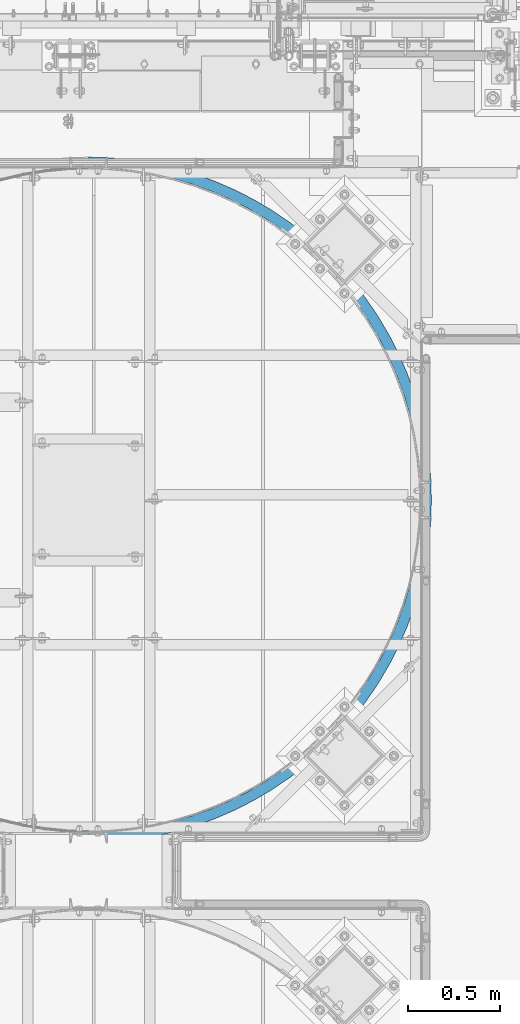
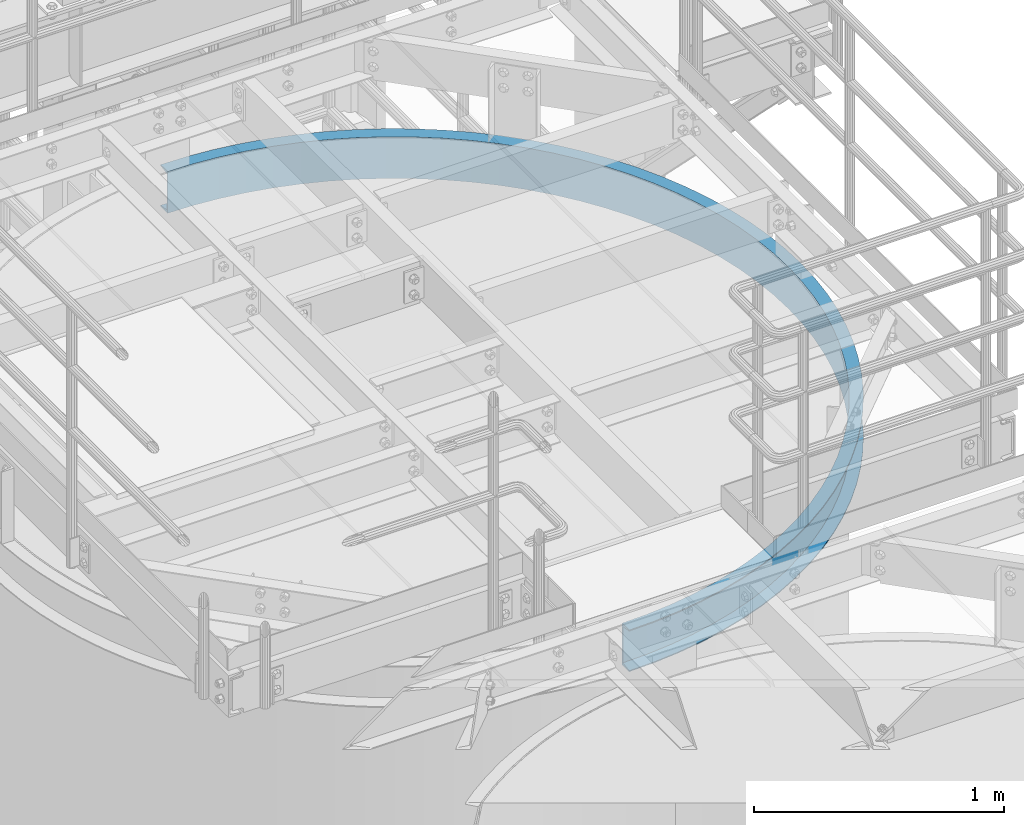
# One storey, part 941 of 1876: 1 beam, 1 element without a shape of its own.
"""IFC2X3 building model written with IfcOpenShell, lengths in millimetres."""

from ifc_helpers import new_model, si_unit, frame, origin_with_axes, place, context, subcontext, project, spatial, faceted_brep, material, type_object, element, aggregate, save


model = new_model("IFC2X3")

# Units and contexts
model_context = context("Model", 3, precision=1e-05, world=origin_with_axes())
body_context = subcontext(model_context, "Body", "Model", "MODEL_VIEW")
ifc_project = project(units=[si_unit("LENGTHUNIT", "METRE", prefix="MILLI"), si_unit("AREAUNIT", "SQUARE_METRE"), si_unit("VOLUMEUNIT", "CUBIC_METRE"), si_unit("MASSUNIT", "GRAM", prefix="KILO"), si_unit("TIMEUNIT", "SECOND"), si_unit("PLANEANGLEUNIT", "RADIAN"), si_unit("SOLIDANGLEUNIT", "STERADIAN"), si_unit("THERMODYNAMICTEMPERATUREUNIT", "DEGREE_CELSIUS"), si_unit("LUMINOUSINTENSITYUNIT", "LUMEN")], contexts=[model_context])

# Site, building, storey
site_placement = place(None, origin_with_axes())
site = spatial("IfcSite", under=ifc_project, at=site_placement, CompositionType="ELEMENT")
building_placement = place(site_placement, origin_with_axes())
building = spatial("IfcBuilding", under=site, at=building_placement, Name="Undefined", CompositionType="ELEMENT")
storey_placement = place(building_placement, origin_with_axes())
storey = spatial("IfcBuildingStorey", under=building, at=storey_placement, Name="Undefined", CompositionType="ELEMENT", Elevation=0.0)

# Assembly, beam
assembly_placement = place(storey_placement, origin_with_axes())
assembly = element("IfcElementAssembly", 1, at=assembly_placement, inside=storey, Name="CHANNEL", AssemblyPlace="NOTDEFINED", PredefinedType="RIGID_FRAME")
ifc_material = material(Name="STEEL/A36")
beam_type = type_object("IfcBeamType", Name="C8X11.5", PredefinedType="NOTDEFINED")
beam_placement = place(assembly_placement, frame((5201.80607653328, -11373.9699317412, 7518.4), z_axis=(0.0, 0.0, 1.0), x_axis=(0.707106781186548, 0.707106781186547, 0.0)))
beam = element("IfcBeam", 2, at=beam_placement, type_object=beam_type, material=ifc_material, Name="CHANNEL", ObjectType="C8X11.5", context=body_context, shape_type="Brep", body=[
    faceted_brep([(-40.4111525448152, -11.8361525448254, -101.6), (-40.4111525448152, -11.8361525448254, -96.8355949999996), (-4.49012806054634, 24.0848719394708, -88.3723149999996), (-4.49012806054634, 24.0848719394708, 88.3723149999996), (-40.4111525448152, -11.8361525448254, 96.8355949999996), (-40.4111525448152, -11.8361525448254, 101.6), (0.0, 28.5749999999998, 101.6), (0.0, 28.5749999999998, -101.6), (83.1681455805992, -49.5250871930584, 101.6), (83.168145580601, -49.5250871930593, -101.6), (45.3741724773627, -92.3939348224612, -101.6), (45.3741724773627, -92.3939348224612, -96.8355949999996), (78.9688152357958, -54.2882924852147, -88.3723149999996), (78.9688152357958, -54.2882924852147, 88.3723149999996), (45.3741724773627, -92.3939348224612, 96.8355949999996), (45.3741724773627, -92.3939348224612, 101.6), (136.048484757743, -167.406249592315, 96.8355949999996), (136.048484757743, -167.406249592315, 101.6), (167.184163083306, -127.266374963614, 88.3723149999996), (167.184163083306, -127.266374963614, -88.3723149999996), (136.048484757743, -167.406249592315, -96.8355949999996), (136.048484757743, -167.406249592315, -101.6), (171.076122874001, -122.248890635026, 101.6), (171.076122874001, -122.248890635026, -101.6), (231.253934210907, -236.577057517859, 96.8355949999996), (231.253934210907, -236.577057517859, 101.6), (259.807769805786, -194.561364344698, 88.3723149999996), (259.807769805786, -194.561364344698, -88.3723149999996), (231.253934210907, -236.577057517859, -96.8355949999996), (231.253934210907, -236.577057517859, -101.6), (263.376999255146, -189.309402698053, 101.6), (263.376999255146, -189.309402698053, -101.6), (330.614788423094, -299.633373021349, 96.8355949999996), (330.614788423094, -299.633373021349, 101.6), (356.474092343207, -255.907678049534, 88.3723149999996), (356.474092343207, -255.907678049534, -88.3723149999996), (330.614788423094, -299.633373021349, -96.8355949999996), (330.614788423094, -299.633373021349, -101.6), (359.706505333223, -250.441966178058, 101.6), (359.706505333223, -250.441966178058, -101.6), (433.738915496391, -356.326341633181, 96.8355949999996), (433.738915496391, -356.326341633181, 101.6), (456.801632883155, -311.063210204398, 88.3723149999996), (456.801632883155, -311.063210204398, -88.3723149999996), (433.738915496391, -356.326341633181, -96.8355949999996), (433.738915496391, -356.326341633181, -101.6), (459.684472556501, -305.4053187758, 101.6), (459.684472556501, -305.4053187758, -101.6), (540.219331614169, -406.432222106796, 96.8355949999996), (540.219331614169, -406.432222106796, 101.6), (560.39444445841, -359.810287122038, 88.3723149999996), (560.39444445841, -359.810287122038, -88.3723149999996), (540.219331614169, -406.432222106796, -96.8355949999996), (540.219331614169, -406.432222106796, -101.6), (562.91633356394, -353.982545248944, 101.6), (562.91633356394, -353.982545248944, -101.6), (649.635807220287, -449.753269423169, 96.8355949999996), (649.635807220287, -449.753269423169, 101.6), (666.843693568744, -401.956526360284, 88.3723149999996), (666.843693568744, -401.956526360284, -88.3723149999996), (649.635807220287, -449.753269423169, -96.8355949999996), (649.635807220287, -449.753269423169, -101.6), (668.9946793623, -395.981933477424, 101.6), (668.9946793623, -395.981933477424, -101.6), (761.556525473163, -486.118515200043, 96.8355949999996), (761.556525473163, -486.118515200043, 101.6), (775.729273659952, -437.335595967645, 88.3723149999996), (775.729273659952, -437.335595967645, -88.3723149999996), (761.556525473163, -486.118515200043, -96.8355949999996), (761.556525473163, -486.118515200043, -101.6), (777.500867183298, -431.237731063595, 101.6), (777.500867183298, -431.237731063595, -101.6), (875.539786429559, -515.384442426039, 96.8355949999996), (875.539786429559, -515.384442426039, 101.6), (886.621463092501, -465.807870919541, 88.3723149999996), (886.621463092501, -465.807870919541, -88.3723149999996), (875.539786429559, -515.384442426039, -96.8355949999996), (875.539786429559, -515.384442426039, -101.6), (888.006672675367, -459.610799481228, 101.6), (888.006672675367, -459.610799481228, -101.6), (991.135750232484, -537.435551856724, 96.8355949999996), (991.135750232484, -537.435551856724, 101.6), (999.082621056526, -487.260984154484, 88.3723149999996), (999.082621056526, -487.260984154484, -88.3723149999996), (991.135750232484, -537.435551856724, -96.8355949999996), (991.135750232484, -537.435551856724, -101.6), (1000.07597990953, -480.989163191702, 101.6), (1000.07597990953, -480.989163191702, -101.6), (1107.88821242358, -552.184817837371, 96.8355949999996), (1107.88821242358, -552.184817837371, 101.6), (1112.66891474016, -501.610270035526, 88.3723149999996), (1112.66891474016, -501.610270035526, -88.3723149999996), (1107.88821242358, -552.184817837371, -96.8355949999996), (1107.88821242358, -552.184817837371, -101.6), (1113.26650252974, -495.288451560295, 101.6), (1113.26650252974, -495.288451560295, -101.6), (1225.33640437371, -559.574031753455, 96.8355949999996), (1225.33640437371, -559.574031753455, 101.6), (1226.93207093488, -508.799098486866, 88.3723149999996), (1226.93207093488, -508.799098486866, -88.3723149999996), (1225.33640437371, -559.574031753455, -96.8355949999996), (1225.33640437371, -559.574031753455, -101.6), (1227.13152925503, -502.452231828542, 101.6), (1227.13152925503, -502.452231828542, -101.6), (1343.01681172622, -559.574031753454, 96.8355949999996), (1343.01681172622, -559.574031753454, 101.6), (1341.42114516505, -508.799098486867, 88.3723149999996), (1341.42114516505, -508.799098486867, -88.3723149999996), (1343.01681172622, -559.574031753454, -96.8355949999996), (1343.01681172622, -559.574031753454, -101.6), (1341.2216868449, -502.452231828544, 101.6), (1341.2216868449, -502.452231828544, -101.6), (1460.46500367634, -552.184817837373, 96.8355949999996), (1460.46500367634, -552.184817837373, 101.6), (1455.68430135976, -501.610270035527, 88.3723149999996), (1455.68430135976, -501.610270035527, -88.3723149999996), (1460.46500367634, -552.184817837373, -96.8355949999996), (1460.46500367634, -552.184817837373, -101.6), (1455.08671357019, -495.288451560297, 101.6), (1455.08671357019, -495.288451560297, -101.6), (1577.21746586744, -537.435551856726, 96.8355949999996), (1577.21746586744, -537.435551856726, 101.6), (1569.2705950434, -487.260984154484, 88.3723149999996), (1569.2705950434, -487.260984154484, -88.3723149999996), (1577.21746586744, -537.435551856726, -96.8355949999996), (1577.21746586744, -537.435551856726, -101.6), (1568.27723619039, -480.989163191705, 101.6), (1568.27723619039, -480.989163191705, -101.6), (1692.81342967037, -515.384442426042, 96.8355949999996), (1692.81342967037, -515.384442426042, 101.6), (1681.73175300743, -465.807870919543, 88.3723149999996), (1681.73175300743, -465.807870919543, -88.3723149999996), (1692.81342967037, -515.384442426042, -96.8355949999996), (1692.81342967037, -515.384442426042, -101.6), (1680.34654342456, -459.610799481231, 101.6), (1680.34654342456, -459.610799481231, -101.6), (1806.79669062676, -486.118515200047, 96.8355949999996), (1806.79669062676, -486.118515200047, 101.6), (1792.62394243998, -437.335595967647, 88.3723149999996), (1792.62394243998, -437.335595967647, -88.3723149999996), (1806.79669062676, -486.118515200047, -96.8355949999996), (1806.79669062676, -486.118515200047, -101.6), (1790.85234891663, -431.237731063598, 101.6), (1790.85234891663, -431.237731063598, -101.6), (1918.71740887964, -449.753269423174, 96.8355949999996), (1918.71740887964, -449.753269423174, 101.6), (1901.50952253118, -401.956526360288, 88.3723149999996), (1901.50952253118, -401.956526360288, -88.3723149999996), (1918.71740887964, -449.753269423174, -96.8355949999996), (1918.71740887964, -449.753269423174, -101.6), (1899.35853673763, -395.981933477428, 101.6), (1899.35853673763, -395.981933477428, -101.6), (2028.13388448576, -406.432222106803, 96.8355949999996), (2028.13388448576, -406.432222106803, 101.6), (2007.95877164152, -359.810287122044, 88.3723149999996), (2007.95877164152, -359.810287122044, -88.3723149999996), (2028.13388448576, -406.432222106803, -96.8355949999996), (2028.13388448576, -406.432222106803, -101.6), (2005.43688253599, -353.982545248949, 101.6), (2005.43688253599, -353.982545248949, -101.6), (2134.61430060353, -356.326341633187, 96.8355949999996), (2134.61430060353, -356.326341633187, 101.6), (2111.55158321677, -311.063210204405, 88.3723149999996), (2111.55158321677, -311.063210204405, -88.3723149999996), (2134.61430060353, -356.326341633187, -96.8355949999996), (2134.61430060353, -356.326341633187, -101.6), (2108.66874354343, -305.405318775807, 101.6), (2108.66874354343, -305.405318775807, -101.6), (2237.73842767683, -299.633373021357, 96.8355949999996), (2237.73842767683, -299.633373021357, 101.6), (2211.87912375672, -255.907678049542, 88.3723149999996), (2211.87912375672, -255.907678049542, -88.3723149999996), (2237.73842767683, -299.633373021357, -96.8355949999996), (2237.73842767683, -299.633373021357, -101.6), (2208.64671076671, -250.441966178065, 101.6), (2208.64671076671, -250.441966178065, -101.6), (2337.09928188902, -236.577057517868, 96.8355949999996), (2337.09928188902, -236.577057517868, 101.6), (2308.54544629414, -194.561364344705, 88.3723149999996), (2308.54544629414, -194.561364344705, -88.3723149999996), (2337.09928188902, -236.577057517868, -96.8355949999996), (2337.09928188902, -236.577057517868, -101.6), (2304.97621684478, -189.30940269806, 101.6), (2304.97621684478, -189.30940269806, -101.6), (2432.30473134219, -167.406249592324, 96.8355949999996), (2432.30473134219, -167.406249592324, 101.6), (2401.16905301662, -127.266374963622, 88.3723149999996), (2401.16905301662, -127.266374963622, -88.3723149999996), (2432.30473134219, -167.406249592324, -96.8355949999996), (2432.30473134219, -167.406249592324, -101.6), (2397.27709322593, -122.248890635034, 101.6), (2397.27709322593, -122.248890635034, -101.6), (2522.97904362256, -92.3939348224685, 96.8355949999996), (2522.97904362256, -92.3939348224685, 101.6), (2489.38440086413, -54.2882924852247, 88.3723149999996), (2489.38440086413, -54.2882924852247, -88.3723149999996), (2522.97904362256, -92.3939348224685, -96.8355949999996), (2522.97904362256, -92.3939348224685, -101.6), (2485.18507051933, -49.5250871930684, 101.6), (2485.18507051933, -49.5250871930684, -101.6), (2608.76436864474, -11.8361525448345, 96.8355949999996), (2608.76436864474, -11.8361525448345, 101.6), (2572.84334416047, 24.0848719394626, 88.3723149999996), (2572.84334416047, 24.0848719394626, -88.3723149999996), (2608.76436864474, -11.8361525448345, -96.8355949999996), (2608.76436864474, -11.8361525448345, -101.6), (2568.35321609994, 28.5749999999989, 101.6), (2568.35321609993, 28.5749999999989, -101.6), (2764.3344656923, 164.623484757718, 101.6), (2833.50527361787, 259.828934210873, 101.6), (2896.56158912139, 359.189788423056, 101.6), (2953.25455773324, 462.313915496351, 101.6), (3003.36043820688, 568.794331614128, 101.6), (3046.68148552328, 678.210807220248, 101.6), (3083.04673130017, 790.131525473126, 101.6), (3112.31265852618, 904.114786429529, 101.6), (3134.36376795688, 1019.71075023246, 101.6), (3149.11303393754, 1136.46321242357, 101.6), (3156.50224785364, 1253.91140437371, 101.6), (3156.50224785364, 1371.59181172622, 101.6), (3149.11303393757, 1489.04000367636, 101.6), (3134.36376795692, 1605.79246586747, 101.6), (3112.31265852624, 1721.38842967041, 101.6), (3083.04673130024, 1835.37169062681, 101.6), (3046.68148552336, 1947.2924088797, 101.6), (3003.36043820698, 2056.70888448582, 101.6), (2953.25455773336, 2163.18930060361, 101.6), (2896.56158912152, 2266.31342767691, 101.6), (2833.50527361802, 2365.67428188911, 101.6), (2764.33446569245, 2460.87973134227, 101.6), (2689.32215092258, 2551.55404362265, 101.6), (2608.76436864493, 2637.33936864483, 101.6), (2568.3532161001, 2596.92821610002, 101.6), (2646.45330329319, 2513.76007051941, 101.6), (2719.17710673517, 2425.85209322601, 101.6), (2786.23761879821, 2333.55121684486, 101.6), (2847.37018227823, 2237.22171076678, 101.6), (2902.33353487598, 2137.2437435435, 101.6), (2950.91076134913, 2034.01188253605, 101.6), (2992.91014957762, 1927.93353673768, 101.6), (3028.16594716379, 1819.42734891668, 101.6), (3056.53901558143, 1708.9215434246, 101.6), (3077.9173792919, 1596.85223619042, 101.6), (3092.21666766049, 1483.66171357021, 101.6), (3099.38044792873, 1369.79668684491, 101.6), (3099.38044792872, 1255.70652925503, 101.6), (3092.21666766047, 1141.84150252973, 101.6), (3077.91737929186, 1028.65097990952, 101.6), (3056.53901558137, 916.581672675346, 101.6), (3028.16594716372, 806.075867183273, 101.6), (2992.91014957753, 697.569679362271, 101.6), (2950.91076134903, 591.49133356391, 101.6), (2902.33353487587, 488.25947255647, 101.6), (2847.3701822781, 388.281505333194, 101.6), (2786.23761879807, 291.951999255124, 101.6), (2719.17710673502, 199.651122873987, 101.6), (2646.45330329302, 111.743145580598, 101.6), (2689.32215092242, 73.9491724773488, 101.6), (2646.45330329302, 111.743145580598, -101.6), (2719.17710673502, 199.651122873987, -101.6), (2786.23761879807, 291.951999255124, -101.6), (2847.3701822781, 388.281505333194, -101.6), (2902.33353487587, 488.25947255647, -101.6), (2950.91076134903, 591.49133356391, -101.6), (2992.91014957753, 697.569679362271, -101.6), (3028.16594716372, 806.075867183273, -101.6), (3056.53901558137, 916.581672675346, -101.6), (3077.91737929186, 1028.65097990952, -101.6), (3092.21666766047, 1141.84150252973, -101.6), (3099.38044792872, 1255.70652925503, -101.6), (3099.38044792873, 1369.79668684491, -101.6), (3092.21666766049, 1483.66171357021, -101.6), (3077.9173792919, 1596.85223619042, -101.6), (3056.53901558143, 1708.9215434246, -101.6), (3028.16594716379, 1819.42734891668, -101.6), (2992.91014957762, 1927.93353673768, -101.6), (2950.91076134913, 2034.01188253605, -101.6), (2902.33353487598, 2137.2437435435, -101.6), (2847.37018227823, 2237.22171076678, -101.6), (2786.23761879821, 2333.55121684486, -101.6), (2719.17710673517, 2425.85209322601, -101.6), (2646.45330329319, 2513.76007051941, -101.6), (2568.3532161001, 2596.92821610002, -101.6), (2608.76436864493, 2637.33936864483, -101.6), (2689.32215092258, 2551.55404362265, -101.6), (2764.33446569245, 2460.87973134227, -101.6), (2833.50527361802, 2365.67428188911, -101.6), (2896.56158912152, 2266.31342767691, -101.6), (2953.25455773336, 2163.18930060361, -101.6), (3003.36043820698, 2056.70888448582, -101.6), (3046.68148552336, 1947.2924088797, -101.6), (3083.04673130024, 1835.37169062681, -101.6), (3112.31265852624, 1721.38842967041, -101.6), (3134.36376795692, 1605.79246586747, -101.6), (3149.11303393757, 1489.04000367636, -101.6), (3156.50224785364, 1371.59181172622, -101.6), (3156.50224785364, 1253.91140437371, -101.6), (3149.11303393754, 1136.46321242357, -101.6), (3134.36376795688, 1019.71075023246, -101.6), (3112.31265852618, 904.114786429529, -101.6), (3083.04673130017, 790.131525473126, -101.6), (3046.68148552328, 678.210807220248, -101.6), (3003.36043820688, 568.794331614128, -101.6), (2953.25455773324, 462.313915496351, -101.6), (2896.56158912139, 359.189788423056, -101.6), (2833.50527361787, 259.828934210873, -101.6), (2764.3344656923, 164.623484757718, -101.6), (2689.32215092242, 73.9491724773488, -101.6), (2689.32215092242, 73.9491724773488, -96.8355949999996), (2651.21650858518, 107.543815235792, -88.3723149999996), (2651.21650858518, 107.543815235792, 88.3723149999996), (2689.32215092242, 73.9491724773488, 96.8355949999996), (2764.3344656923, 164.623484757718, 96.8355949999996), (2724.19459106361, 195.75916308329, 88.3723149999996), (2724.19459106361, 195.75916308329, -88.3723149999996), (2764.3344656923, 164.623484757718, -96.8355949999996), (2833.50527361787, 259.828934210873, 96.8355949999996), (2791.48958044472, 288.382769805763, 88.3723149999996), (2791.48958044472, 288.382769805763, -88.3723149999996), (2833.50527361787, 259.828934210873, -96.8355949999996), (2896.56158912139, 359.189788423056, 96.8355949999996), (2852.83589414958, 385.049092343178, 88.3723149999996), (2852.83589414958, 385.049092343178, -88.3723149999996), (2896.56158912139, 359.189788423056, -96.8355949999996), (2953.25455773324, 462.313915496351, 96.8355949999996), (2907.99142630447, 485.376632883123, 88.3723149999996), (2907.99142630447, 485.376632883123, -88.3723149999996), (2953.25455773324, 462.313915496351, -96.8355949999996), (3003.36043820688, 568.794331614128, 96.8355949999996), (2956.73850322213, 588.969444458379, 88.3723149999996), (2956.73850322213, 588.969444458379, -88.3723149999996), (3003.36043820688, 568.794331614128, -96.8355949999996), (3046.68148552328, 678.210807220248, 96.8355949999996), (2998.88474246039, 695.418693568713, 88.3723149999996), (2998.88474246039, 695.418693568713, -88.3723149999996), (3046.68148552328, 678.210807220248, -96.8355949999996), (3083.04673130017, 790.131525473126, 96.8355949999996), (3034.26381206777, 804.304273659922, 88.3723149999996), (3034.26381206777, 804.304273659922, -88.3723149999996), (3083.04673130017, 790.131525473126, -96.8355949999996), (3112.31265852618, 904.114786429529, 96.8355949999996), (3062.73608701968, 915.196463092477, 88.3723149999996), (3062.73608701968, 915.196463092477, -88.3723149999996), (3112.31265852618, 904.114786429529, -96.8355949999996), (3134.36376795688, 1019.71075023246, 96.8355949999996), (3084.18920025464, 1027.65762105651, 88.3723149999996), (3084.18920025464, 1027.65762105651, -88.3723149999996), (3134.36376795688, 1019.71075023246, -96.8355949999996), (3149.11303393754, 1136.46321242357, 96.8355949999996), (3098.5384861357, 1141.24391474015, 88.3723149999996), (3098.5384861357, 1141.24391474015, -88.3723149999996), (3149.11303393754, 1136.46321242357, -96.8355949999996), (3156.50224785364, 1253.91140437371, 96.8355949999996), (3105.72731458705, 1255.50707093488, 88.3723149999996), (3105.72731458705, 1255.50707093488, -88.3723149999996), (3156.50224785364, 1253.91140437371, -96.8355949999996), (3156.50224785364, 1371.59181172622, 96.8355949999996), (3105.72731458705, 1369.99614516506, 88.3723149999996), (3105.72731458705, 1369.99614516506, -88.3723149999996), (3156.50224785364, 1371.59181172622, -96.8355949999996), (3149.11303393757, 1489.04000367636, 96.8355949999996), (3098.53848613572, 1484.25930135978, 88.3723149999996), (3098.53848613572, 1484.25930135978, -88.3723149999996), (3149.11303393757, 1489.04000367636, -96.8355949999996), (3134.36376795692, 1605.79246586747, 96.8355949999996), (3084.18920025468, 1597.84559504343, 88.3723149999996), (3084.18920025468, 1597.84559504343, -88.3723149999996), (3134.36376795692, 1605.79246586747, -96.8355949999996), (3112.31265852624, 1721.38842967041, 96.8355949999996), (3062.73608701974, 1710.30675300747, 88.3723149999996), (3062.73608701974, 1710.30675300747, -88.3723149999996), (3112.31265852624, 1721.38842967041, -96.8355949999996), (3083.04673130024, 1835.37169062681, 96.8355949999996), (3034.26381206784, 1821.19894244003, 88.3723149999996), (3034.26381206784, 1821.19894244003, -88.3723149999996), (3083.04673130024, 1835.37169062681, -96.8355949999996), (3046.68148552336, 1947.2924088797, 96.8355949999996), (2998.88474246048, 1930.08452253124, 88.3723149999996), (2998.88474246048, 1930.08452253124, -88.3723149999996), (3046.68148552336, 1947.2924088797, -96.8355949999996), (3003.36043820698, 2056.70888448582, 96.8355949999996), (2956.73850322223, 2036.53377164158, 88.3723149999996), (2956.73850322223, 2036.53377164158, -88.3723149999996), (3003.36043820698, 2056.70888448582, -96.8355949999996), (2953.25455773336, 2163.18930060361, 96.8355949999996), (2907.99142630458, 2140.12658321685, 88.3723149999996), (2907.99142630458, 2140.12658321685, -88.3723149999996), (2953.25455773336, 2163.18930060361, -96.8355949999996), (2896.56158912152, 2266.31342767691, 96.8355949999996), (2852.8358941497, 2240.4541237568, 88.3723149999996), (2852.8358941497, 2240.4541237568, -88.3723149999996), (2896.56158912152, 2266.31342767691, -96.8355949999996), (2833.50527361802, 2365.67428188911, 96.8355949999996), (2791.48958044486, 2337.12044629422, 88.3723149999996), (2791.48958044486, 2337.12044629422, -88.3723149999996), (2833.50527361802, 2365.67428188911, -96.8355949999996), (2764.33446569245, 2460.87973134227, 96.8355949999996), (2724.19459106376, 2429.74405301671, 88.3723149999996), (2724.19459106376, 2429.74405301671, -88.3723149999996), (2764.33446569245, 2460.87973134227, -96.8355949999996), (2689.32215092258, 2551.55404362265, 96.8355949999996), (2651.21650858534, 2517.95940086422, 88.3723149999996), (2651.21650858534, 2517.95940086422, -88.3723149999996), (2689.32215092258, 2551.55404362265, -96.8355949999996), (2608.76436864493, 2637.33936864483, 96.8355949999996), (2572.84334416064, 2601.41834416056, 88.3723149999996), (2572.84334416064, 2601.41834416056, -88.3723149999996), (2608.76436864493, 2637.33936864483, -96.8355949999996)], [[[0, 1, 2, 3, 4, 5, 6, 7]], [[7, 6, 8, 9]], [[1, 0, 10, 11]], [[2, 1, 11, 12]], [[3, 2, 12, 13]], [[4, 3, 13, 14]], [[5, 4, 14, 15]], [[14, 16, 17, 15]], [[13, 18, 16, 14]], [[12, 19, 18, 13]], [[11, 20, 19, 12]], [[10, 21, 20, 11]], [[8, 22, 23, 9]], [[16, 24, 25, 17]], [[18, 26, 24, 16]], [[19, 27, 26, 18]], [[20, 28, 27, 19]], [[21, 29, 28, 20]], [[22, 30, 31, 23]], [[24, 32, 33, 25]], [[26, 34, 32, 24]], [[27, 35, 34, 26]], [[28, 36, 35, 27]], [[29, 37, 36, 28]], [[30, 38, 39, 31]], [[32, 40, 41, 33]], [[34, 42, 40, 32]], [[35, 43, 42, 34]], [[36, 44, 43, 35]], [[37, 45, 44, 36]], [[38, 46, 47, 39]], [[40, 48, 49, 41]], [[42, 50, 48, 40]], [[43, 51, 50, 42]], [[44, 52, 51, 43]], [[45, 53, 52, 44]], [[46, 54, 55, 47]], [[48, 56, 57, 49]], [[50, 58, 56, 48]], [[51, 59, 58, 50]], [[52, 60, 59, 51]], [[53, 61, 60, 52]], [[54, 62, 63, 55]], [[56, 64, 65, 57]], [[58, 66, 64, 56]], [[59, 67, 66, 58]], [[60, 68, 67, 59]], [[61, 69, 68, 60]], [[62, 70, 71, 63]], [[64, 72, 73, 65]], [[66, 74, 72, 64]], [[67, 75, 74, 66]], [[68, 76, 75, 67]], [[69, 77, 76, 68]], [[70, 78, 79, 71]], [[72, 80, 81, 73]], [[74, 82, 80, 72]], [[75, 83, 82, 74]], [[76, 84, 83, 75]], [[77, 85, 84, 76]], [[78, 86, 87, 79]], [[80, 88, 89, 81]], [[82, 90, 88, 80]], [[83, 91, 90, 82]], [[84, 92, 91, 83]], [[85, 93, 92, 84]], [[86, 94, 95, 87]], [[88, 96, 97, 89]], [[90, 98, 96, 88]], [[91, 99, 98, 90]], [[92, 100, 99, 91]], [[93, 101, 100, 92]], [[94, 102, 103, 95]], [[96, 104, 105, 97]], [[98, 106, 104, 96]], [[99, 107, 106, 98]], [[100, 108, 107, 99]], [[101, 109, 108, 100]], [[102, 110, 111, 103]], [[104, 112, 113, 105]], [[106, 114, 112, 104]], [[107, 115, 114, 106]], [[108, 116, 115, 107]], [[109, 117, 116, 108]], [[110, 118, 119, 111]], [[112, 120, 121, 113]], [[114, 122, 120, 112]], [[115, 123, 122, 114]], [[116, 124, 123, 115]], [[117, 125, 124, 116]], [[118, 126, 127, 119]], [[120, 128, 129, 121]], [[122, 130, 128, 120]], [[123, 131, 130, 122]], [[124, 132, 131, 123]], [[125, 133, 132, 124]], [[126, 134, 135, 127]], [[128, 136, 137, 129]], [[130, 138, 136, 128]], [[131, 139, 138, 130]], [[132, 140, 139, 131]], [[133, 141, 140, 132]], [[134, 142, 143, 135]], [[136, 144, 145, 137]], [[138, 146, 144, 136]], [[139, 147, 146, 138]], [[140, 148, 147, 139]], [[141, 149, 148, 140]], [[142, 150, 151, 143]], [[144, 152, 153, 145]], [[146, 154, 152, 144]], [[147, 155, 154, 146]], [[148, 156, 155, 147]], [[149, 157, 156, 148]], [[150, 158, 159, 151]], [[152, 160, 161, 153]], [[154, 162, 160, 152]], [[155, 163, 162, 154]], [[156, 164, 163, 155]], [[157, 165, 164, 156]], [[158, 166, 167, 159]], [[160, 168, 169, 161]], [[162, 170, 168, 160]], [[163, 171, 170, 162]], [[164, 172, 171, 163]], [[165, 173, 172, 164]], [[166, 174, 175, 167]], [[168, 176, 177, 169]], [[170, 178, 176, 168]], [[171, 179, 178, 170]], [[172, 180, 179, 171]], [[173, 181, 180, 172]], [[174, 182, 183, 175]], [[176, 184, 185, 177]], [[178, 186, 184, 176]], [[179, 187, 186, 178]], [[180, 188, 187, 179]], [[181, 189, 188, 180]], [[182, 190, 191, 183]], [[184, 192, 193, 185]], [[186, 194, 192, 184]], [[187, 195, 194, 186]], [[188, 196, 195, 187]], [[189, 197, 196, 188]], [[190, 198, 199, 191]], [[192, 200, 201, 193]], [[194, 202, 200, 192]], [[195, 203, 202, 194]], [[196, 204, 203, 195]], [[197, 205, 204, 196]], [[198, 206, 207, 199]], [[208, 209, 210, 211, 212, 213, 214, 215, 216, 217, 218, 219, 220, 221, 222, 223, 224, 225, 226, 227, 228, 229, 230, 231, 232, 233, 234, 235, 236, 237, 238, 239, 240, 241, 242, 243, 244, 245, 246, 247, 248, 249, 250, 251, 252, 253, 254, 255, 256, 206, 198, 190, 182, 174, 166, 158, 150, 142, 134, 126, 118, 110, 102, 94, 86, 78, 70, 62, 54, 46, 38, 30, 22, 8, 6, 5, 15, 17, 25, 33, 41, 49, 57, 65, 73, 81, 89, 97, 105, 113, 121, 129, 137, 145, 153, 161, 169, 177, 185, 193, 201, 257]], [[207, 206, 256, 258]], [[259, 260, 261, 262, 263, 264, 265, 266, 267, 268, 269, 270, 271, 272, 273, 274, 275, 276, 277, 278, 279, 280, 281, 282, 283, 284, 285, 286, 287, 288, 289, 290, 291, 292, 293, 294, 295, 296, 297, 298, 299, 300, 301, 302, 303, 304, 305, 306, 307, 205, 197, 189, 181, 173, 165, 157, 149, 141, 133, 125, 117, 109, 101, 93, 85, 77, 69, 61, 53, 45, 37, 29, 21, 10, 0, 7, 9, 23, 31, 39, 47, 55, 63, 71, 79, 87, 95, 103, 111, 119, 127, 135, 143, 151, 159, 167, 175, 183, 191, 199, 207, 258]], [[204, 205, 307, 308]], [[203, 204, 308, 309]], [[202, 203, 309, 310]], [[200, 202, 310, 311]], [[201, 200, 311, 257]], [[311, 312, 208, 257]], [[310, 313, 312, 311]], [[309, 314, 313, 310]], [[308, 315, 314, 309]], [[307, 306, 315, 308]], [[256, 255, 259, 258]], [[312, 316, 209, 208]], [[313, 317, 316, 312]], [[314, 318, 317, 313]], [[315, 319, 318, 314]], [[306, 305, 319, 315]], [[255, 254, 260, 259]], [[316, 320, 210, 209]], [[317, 321, 320, 316]], [[318, 322, 321, 317]], [[319, 323, 322, 318]], [[305, 304, 323, 319]], [[254, 253, 261, 260]], [[320, 324, 211, 210]], [[321, 325, 324, 320]], [[322, 326, 325, 321]], [[323, 327, 326, 322]], [[304, 303, 327, 323]], [[253, 252, 262, 261]], [[324, 328, 212, 211]], [[325, 329, 328, 324]], [[326, 330, 329, 325]], [[327, 331, 330, 326]], [[303, 302, 331, 327]], [[252, 251, 263, 262]], [[328, 332, 213, 212]], [[329, 333, 332, 328]], [[330, 334, 333, 329]], [[331, 335, 334, 330]], [[302, 301, 335, 331]], [[251, 250, 264, 263]], [[332, 336, 214, 213]], [[333, 337, 336, 332]], [[334, 338, 337, 333]], [[335, 339, 338, 334]], [[301, 300, 339, 335]], [[250, 249, 265, 264]], [[336, 340, 215, 214]], [[337, 341, 340, 336]], [[338, 342, 341, 337]], [[339, 343, 342, 338]], [[300, 299, 343, 339]], [[249, 248, 266, 265]], [[340, 344, 216, 215]], [[341, 345, 344, 340]], [[342, 346, 345, 341]], [[343, 347, 346, 342]], [[299, 298, 347, 343]], [[248, 247, 267, 266]], [[344, 348, 217, 216]], [[345, 349, 348, 344]], [[346, 350, 349, 345]], [[347, 351, 350, 346]], [[298, 297, 351, 347]], [[247, 246, 268, 267]], [[348, 352, 218, 217]], [[349, 353, 352, 348]], [[350, 354, 353, 349]], [[351, 355, 354, 350]], [[297, 296, 355, 351]], [[246, 245, 269, 268]], [[352, 356, 219, 218]], [[353, 357, 356, 352]], [[354, 358, 357, 353]], [[355, 359, 358, 354]], [[296, 295, 359, 355]], [[245, 244, 270, 269]], [[356, 360, 220, 219]], [[357, 361, 360, 356]], [[358, 362, 361, 357]], [[359, 363, 362, 358]], [[295, 294, 363, 359]], [[244, 243, 271, 270]], [[360, 364, 221, 220]], [[361, 365, 364, 360]], [[362, 366, 365, 361]], [[363, 367, 366, 362]], [[294, 293, 367, 363]], [[243, 242, 272, 271]], [[364, 368, 222, 221]], [[365, 369, 368, 364]], [[366, 370, 369, 365]], [[367, 371, 370, 366]], [[293, 292, 371, 367]], [[242, 241, 273, 272]], [[368, 372, 223, 222]], [[369, 373, 372, 368]], [[370, 374, 373, 369]], [[371, 375, 374, 370]], [[292, 291, 375, 371]], [[241, 240, 274, 273]], [[372, 376, 224, 223]], [[373, 377, 376, 372]], [[374, 378, 377, 373]], [[375, 379, 378, 374]], [[291, 290, 379, 375]], [[240, 239, 275, 274]], [[376, 380, 225, 224]], [[377, 381, 380, 376]], [[378, 382, 381, 377]], [[379, 383, 382, 378]], [[290, 289, 383, 379]], [[239, 238, 276, 275]], [[380, 384, 226, 225]], [[381, 385, 384, 380]], [[382, 386, 385, 381]], [[383, 387, 386, 382]], [[289, 288, 387, 383]], [[238, 237, 277, 276]], [[384, 388, 227, 226]], [[385, 389, 388, 384]], [[386, 390, 389, 385]], [[387, 391, 390, 386]], [[288, 287, 391, 387]], [[237, 236, 278, 277]], [[388, 392, 228, 227]], [[389, 393, 392, 388]], [[390, 394, 393, 389]], [[391, 395, 394, 390]], [[287, 286, 395, 391]], [[236, 235, 279, 278]], [[392, 396, 229, 228]], [[393, 397, 396, 392]], [[394, 398, 397, 393]], [[395, 399, 398, 394]], [[286, 285, 399, 395]], [[235, 234, 280, 279]], [[396, 400, 230, 229]], [[397, 401, 400, 396]], [[398, 402, 401, 397]], [[399, 403, 402, 398]], [[285, 284, 403, 399]], [[234, 233, 281, 280]], [[231, 404, 405, 406, 407, 283, 282, 232]], [[400, 404, 231, 230]], [[401, 405, 404, 400]], [[402, 406, 405, 401]], [[403, 407, 406, 402]], [[284, 283, 407, 403]], [[233, 232, 282, 281]]]),
])
aggregate(assembly, [beam])

save(model, "model.ifc")
